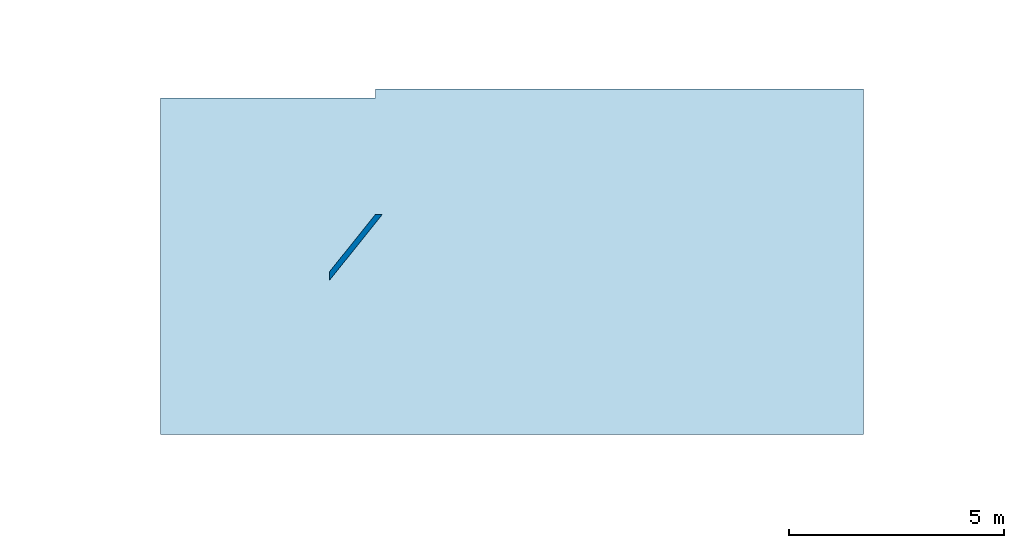
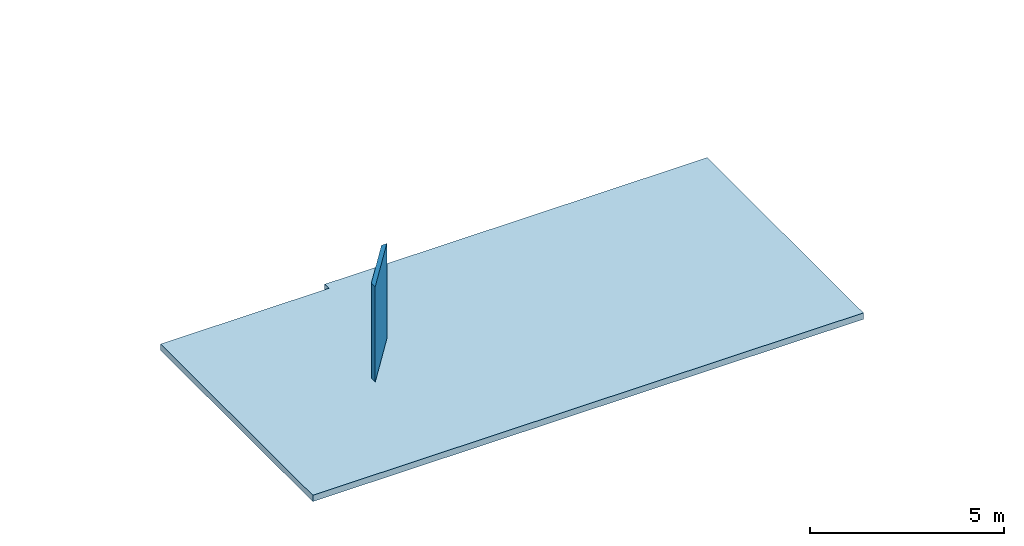
# One storey, part 1 of 38: 1 slab, 1 wall.
"""IFC4 building model written with IfcOpenShell, lengths in feet."""

from ifc_helpers import new_model, entity, si_unit, converted_unit, frame, origin_with_axes, origin_2d_with_axis, place, context, subcontext, project, spatial, line, indexed_curve, outline, extrude, clip, halfspace, material, layer, layer_set, layer_usage, type_object, element, save


model = new_model("IFC4")

# Units and contexts
model_context = context("Model", 3, precision=1e-05, world=origin_with_axes())
plan_context = context("Plan", 2, precision=1e-05, world=origin_2d_with_axis())
context_of_model_1 = context(None, 3, precision=1e-05, world=origin_with_axes())
context_of_model_2 = context(None, 3, precision=1e-05, world=origin_with_axes())
body_context = subcontext(model_context, "Body", "Model", "MODEL_VIEW")
ifc_project = project(units=[converted_unit("PLANEANGLEUNIT", "degree", entity("IfcReal", 0.0174532925199433), si_unit("PLANEANGLEUNIT", "RADIAN"), dimensions=[0, 0, 0, 0, 0, 0, 0]), converted_unit("AREAUNIT", "square foot", entity("IfcReal", 0.09290304), si_unit("AREAUNIT", "SQUARE_METRE"), dimensions=[2, 0, 0, 0, 0, 0, 0]), converted_unit("LENGTHUNIT", "foot", entity("IfcReal", 0.3048), si_unit("LENGTHUNIT", "METRE"), dimensions=[1, 0, 0, 0, 0, 0, 0]), converted_unit("VOLUMEUNIT", "cubic foot", entity("IfcReal", 0.0283168467116885), si_unit("VOLUMEUNIT", "CUBIC_METRE"), dimensions=[3, 0, 0, 0, 0, 0, 0])], contexts=[model_context, plan_context, context_of_model_1, context_of_model_2])

# Site, building, storey
site_placement = place(None, origin_with_axes())
site = spatial("IfcSite", under=ifc_project, at=site_placement)
building_placement = place(site_placement, origin_with_axes())
building = spatial("IfcBuilding", under=site, at=building_placement, Name="Building")
storey_placement = place(building_placement, origin_with_axes())
storey = spatial("IfcBuildingStorey", under=building, at=storey_placement, Name="Storey")

# Slab
ifc_material_1 = material(Name="GENERIC_FLOOR", Category="floor")
ifc_layer_1 = layer(ifc_material_1, 0.656167984008789, Name="Floor_LayerName")
ifc_layer_set_1 = layer_set([ifc_layer_1], Name="Floor_LayerSetName")
ifc_layer_usage_1 = layer_usage(ifc_layer_set_1, "AXIS3", "POSITIVE", 0.0)
slab_type = type_object("IfcSlabType", Name="FLR150", PredefinedType="NOTDEFINED", material=ifc_layer_set_1)
slab_placement = place(storey_placement, frame((73.8413377696761, 37.0925743123052, -0.656167548785372), z_axis=(0.0, 0.0, 1.0), x_axis=(1.0, 0.0, 0.0)))
element("IfcSlab", 1, at=slab_placement, inside=storey, type_object=slab_type, material=ifc_layer_usage_1, Name="Slab", context=body_context, shape_type="SweptSolid", body=[
    extrude(outline(indexed_curve([(-26.8299560847245, -12.1075650212646), (26.9120884692575, -12.1075650212646), (26.9120884692575, 14.3191914545895), (-26.8299560847245, 13.6261130255351), (-10.4084071211928, 14.3191914545895), (-10.4084118144719, 13.6261130255351)], segments=[line(3, 5), line(5, 6), line(6, 4), line(4, 1), line(1, 2), line(2, 3)], self_intersect=False)), None, (0.0, 0.0, 1.0), 0.656167979002625),
])

# Wall
ifc_material_2 = material(Category="Materials")
ifc_layer_2 = layer(ifc_material_2, 0.0520833333333333, Category="Materials")
ifc_material_3 = material(Category="Materials")
ifc_layer_3 = layer(ifc_material_3, 0.302083333333333, Category="Materials")
ifc_layer_4 = layer(ifc_material_2, 0.0520833333333333, Category="Materials")
ifc_layer_set_2 = layer_set([ifc_layer_2, ifc_layer_3, ifc_layer_4], Name="poche")
ifc_layer_usage_2 = layer_usage(ifc_layer_set_2, "AXIS2", "POSITIVE", 0.0)
wall_type = type_object("IfcWallType", Name="W1", PredefinedType="STANDARD", material=ifc_layer_set_2)
wall_placement = place(storey_placement, frame((59.5113361288556, 36.2762190851327, 3.91106593014374e-07), z_axis=(0.0, 0.0, 1.0), x_axis=(0.625427393757429, 0.780282368849758, 0.0)))
element("IfcWall", 2, at=wall_placement, inside=storey, type_object=wall_type, material=ifc_layer_usage_2, Name="Wall", context=body_context, shape_type="Clipping", body=[
    clip(clip(extrude(outline(indexed_curve([(0.0, 0.0), (0.0, 0.40625), (7.62337374211817, 0.40625), (7.62337374211817, 0.0), (0.0, 0.0)], self_intersect=False)), origin_with_axes(), (0.0, 0.0, 1.0), 9.84251976013184), halfspace(frame((0.649559216236505, -1.5644263720575e-06, -3.91106593014374e-07), z_axis=(-0.371475219726562, 0.463451951742172, 0.0), x_axis=(0.15448397397995, 0.123825073242188, 0.0)), False)), halfspace(frame((7.10273039309684, 1.5644263720575e-06, -3.91106593014374e-07), z_axis=(0.371472358703613, 0.297749906778336, 0.0), x_axis=(-0.099249966442585, 0.123824119567871, 0.0)), False)),
])

save(model, "model.ifc")
